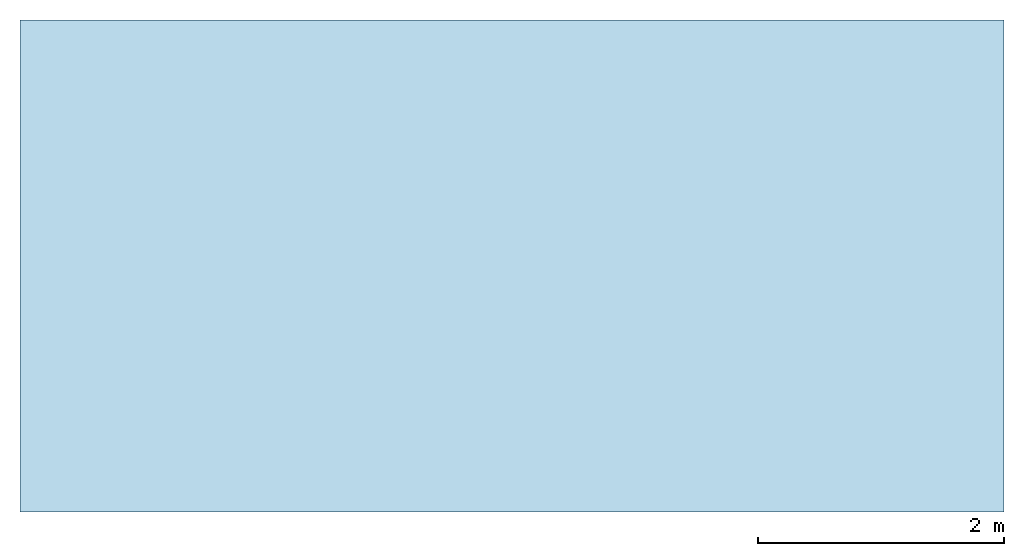
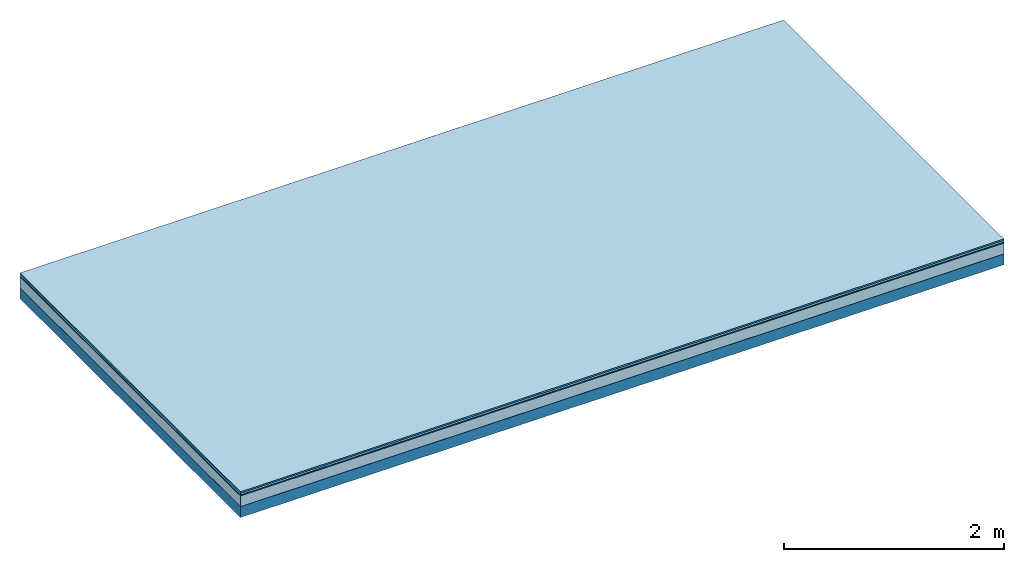
# One storey: 5 plates, 1 member, 1 element without a shape of its own.
"""IFC4 building model written with IfcOpenShell, lengths in metres."""

from ifc_helpers import new_model, si_unit, derived_unit, direction, frame, frame_2d, origin, origin_with_axes, place, context, project, spatial, rectangle, extrude, material, layer, layer_set, type_object, element, aggregate, save


model = new_model("IFC4")

# Units and contexts
plan_context = context("Plan", 3, precision=1e-05, world=origin(), true_north=direction((0.0, 1.0)))
model_context = context("Model", 3, precision=1e-05, world=origin(), true_north=direction((0.0, 1.0)))
ifc_project = project(units=[si_unit("LENGTHUNIT", "METRE"), derived_unit("SOUNDPRESSUREUNIT", [(si_unit("PRESSUREUNIT", "PASCAL", prefix="MICRO"), 0)]), si_unit("ENERGYUNIT", "JOULE", prefix="MEGA"), si_unit("MASSUNIT", "GRAM", prefix="KILO"), derived_unit("THERMALTRANSMITTANCEUNIT", [(si_unit("POWERUNIT", "WATT"), 1), (si_unit("AREAUNIT", "SQUARE_METRE"), -1), (si_unit("THERMODYNAMICTEMPERATUREUNIT", "KELVIN"), -1)]), derived_unit("AREADENSITYUNIT", [(si_unit("MASSUNIT", "GRAM", prefix="KILO"), 1), (si_unit("AREAUNIT", "SQUARE_METRE"), -1)]), derived_unit("USERDEFINED", [(si_unit("ENERGYUNIT", "JOULE", prefix="MEGA"), 1), (si_unit("AREAUNIT", "SQUARE_METRE"), -1)])], contexts=[plan_context, model_context])

# Site, building, storey
site = spatial("IfcSite", under=ifc_project)
building_placement = place(None, origin())
building = spatial("IfcBuilding", under=site, at=building_placement)
storey_placement = place(building_placement, origin())
storey = spatial("IfcBuildingStorey", under=building, at=storey_placement)

# Slab, member, plates
ifc_material_1 = material(Category="11.013")
ifc_layer_1 = layer(ifc_material_1, 0.015, Name="Flooring")
ifc_material_2 = material(Category="03.007")
ifc_layer_2 = layer(ifc_material_2, 0.02, Name="On-material")
ifc_material_3 = material(Name="Wood fiber generic product", Category="10.009")
ifc_layer_3 = layer(ifc_material_3, 0.01, Name="Impact sound insulation")
ifc_material_4 = material(Category="03.011")
ifc_layer_4 = layer(ifc_material_4, 0.12, Name="on Supporting structure")
ifc_material_5 = material(Name="protection", Category="09.007")
ifc_layer_5 = layer(ifc_material_5, 0.0005, Name="Sub-floor")
ifc_material_6 = material(Name="no composite action")
ifc_layer_6 = layer(ifc_material_6, 0.0, Name="Bond")
ifc_layer_7 = layer(None, 0.12, Name="Supporting structure")
ifc_layer_set = layer_set([ifc_layer_1, ifc_layer_2, ifc_layer_3, ifc_layer_4, ifc_layer_5, ifc_layer_6, ifc_layer_7])
slab_type = type_object("IfcSlabType", Name="A2051", PredefinedType="NOTDEFINED", material=ifc_layer_set)
slab_placement = place(None, frame((0.0, 0.0, 0.0), z_axis=(0.0, 0.0, -1.0), x_axis=(1.0, 0.0, 0.0)))
slab = element("IfcSlab", 1, at=slab_placement, inside=storey, type_object=slab_type, material=ifc_layer_set, Name="Slab #1")
ifc_material_7 = material(Name="Solid timber panel")
member_placement = place(slab_placement, origin())
member = element("IfcMember", 2, at=member_placement, material=ifc_material_7, Name="Supporting structure", context=plan_context, shape_type="SweptSolid", body=[
    extrude(rectangle(XDim=1.0, YDim=0.12, at=frame_2d((0.5, 0.06), x_axis=(1.0, 0.0))), frame((0.0, 4.0, 0.1655), z_axis=(0.0, -1.0, 0.0), x_axis=(1.0, 0.0, 0.0)), (0.0, 0.0, 1.0), 4.0),
    extrude(rectangle(XDim=1.0, YDim=0.12, at=frame_2d((0.5, 0.06), x_axis=(1.0, 0.0))), frame((1.0, 4.0, 0.1655), z_axis=(0.0, -1.0, 0.0), x_axis=(1.0, 0.0, 0.0)), (0.0, 0.0, 1.0), 4.0),
    extrude(rectangle(XDim=1.0, YDim=0.12, at=frame_2d((0.5, 0.06), x_axis=(1.0, 0.0))), frame((2.0, 4.0, 0.1655), z_axis=(0.0, -1.0, 0.0), x_axis=(1.0, 0.0, 0.0)), (0.0, 0.0, 1.0), 4.0),
    extrude(rectangle(XDim=1.0, YDim=0.12, at=frame_2d((0.5, 0.06), x_axis=(1.0, 0.0))), frame((3.0, 4.0, 0.1655), z_axis=(0.0, -1.0, 0.0), x_axis=(1.0, 0.0, 0.0)), (0.0, 0.0, 1.0), 4.0),
    extrude(rectangle(XDim=1.0, YDim=0.12, at=frame_2d((0.5, 0.06), x_axis=(1.0, 0.0))), frame((4.0, 4.0, 0.1655), z_axis=(0.0, -1.0, 0.0), x_axis=(1.0, 0.0, 0.0)), (0.0, 0.0, 1.0), 4.0),
    extrude(rectangle(XDim=1.0, YDim=0.12, at=frame_2d((0.5, 0.06), x_axis=(1.0, 0.0))), frame((5.0, 4.0, 0.1655), z_axis=(0.0, -1.0, 0.0), x_axis=(1.0, 0.0, 0.0)), (0.0, 0.0, 1.0), 4.0),
    extrude(rectangle(XDim=1.0, YDim=0.12, at=frame_2d((0.5, 0.06), x_axis=(1.0, 0.0))), frame((6.0, 4.0, 0.1655), z_axis=(0.0, -1.0, 0.0), x_axis=(1.0, 0.0, 0.0)), (0.0, 0.0, 1.0), 4.0),
    extrude(rectangle(XDim=1.0, YDim=0.12, at=frame_2d((0.5, 0.06), x_axis=(1.0, 0.0))), frame((7.0, 4.0, 0.1655), z_axis=(0.0, -1.0, 0.0), x_axis=(1.0, 0.0, 0.0)), (0.0, 0.0, 1.0), 4.0),
])
plate_1_placement = place(slab_placement, origin())
plate_1 = element("IfcPlate", 3, at=plate_1_placement, material=ifc_material_1, Name="Flooring", context=plan_context, shape_type="SweptSolid", body=[
    extrude(rectangle(XDim=8.0, YDim=4.0, at=frame_2d((4.0, 2.0), x_axis=(1.0, 0.0))), origin_with_axes(), (0.0, 0.0, 1.0), 0.015),
])
plate_2_placement = place(slab_placement, origin())
plate_2 = element("IfcPlate", 4, at=plate_2_placement, material=ifc_material_2, Name="On-material", context=plan_context, shape_type="SweptSolid", body=[
    extrude(rectangle(XDim=8.0, YDim=4.0, at=frame_2d((4.0, 2.0), x_axis=(1.0, 0.0))), frame((0.0, 0.0, 0.015), z_axis=(0.0, 0.0, 1.0), x_axis=(1.0, 0.0, 0.0)), (0.0, 0.0, 1.0), 0.02),
])
plate_3_placement = place(slab_placement, origin())
plate_3 = element("IfcPlate", 5, at=plate_3_placement, material=ifc_material_3, Name="Impact sound insulation", context=plan_context, shape_type="SweptSolid", body=[
    extrude(rectangle(XDim=8.0, YDim=4.0, at=frame_2d((4.0, 2.0), x_axis=(1.0, 0.0))), frame((0.0, 0.0, 0.035), z_axis=(0.0, 0.0, 1.0), x_axis=(1.0, 0.0, 0.0)), (0.0, 0.0, 1.0), 0.01),
])
plate_4_placement = place(slab_placement, origin())
plate_4 = element("IfcPlate", 6, at=plate_4_placement, material=ifc_material_4, Name="on Supporting structure", context=plan_context, shape_type="SweptSolid", body=[
    extrude(rectangle(XDim=8.0, YDim=4.0, at=frame_2d((4.0, 2.0), x_axis=(1.0, 0.0))), frame((0.0, 0.0, 0.045), z_axis=(0.0, 0.0, 1.0), x_axis=(1.0, 0.0, 0.0)), (0.0, 0.0, 1.0), 0.12),
])
plate_5_placement = place(slab_placement, origin())
plate_5 = element("IfcPlate", 7, at=plate_5_placement, material=ifc_material_5, Name="Sub-floor", context=plan_context, shape_type="SweptSolid", body=[
    extrude(rectangle(XDim=8.0, YDim=4.0, at=frame_2d((4.0, 2.0), x_axis=(1.0, 0.0))), frame((0.0, 0.0, 0.165), z_axis=(0.0, 0.0, 1.0), x_axis=(1.0, 0.0, 0.0)), (0.0, 0.0, 1.0), 0.0005),
])
aggregate(slab, [plate_1, plate_2, plate_3, plate_4, plate_5, member])

save(model, "model.ifc")
